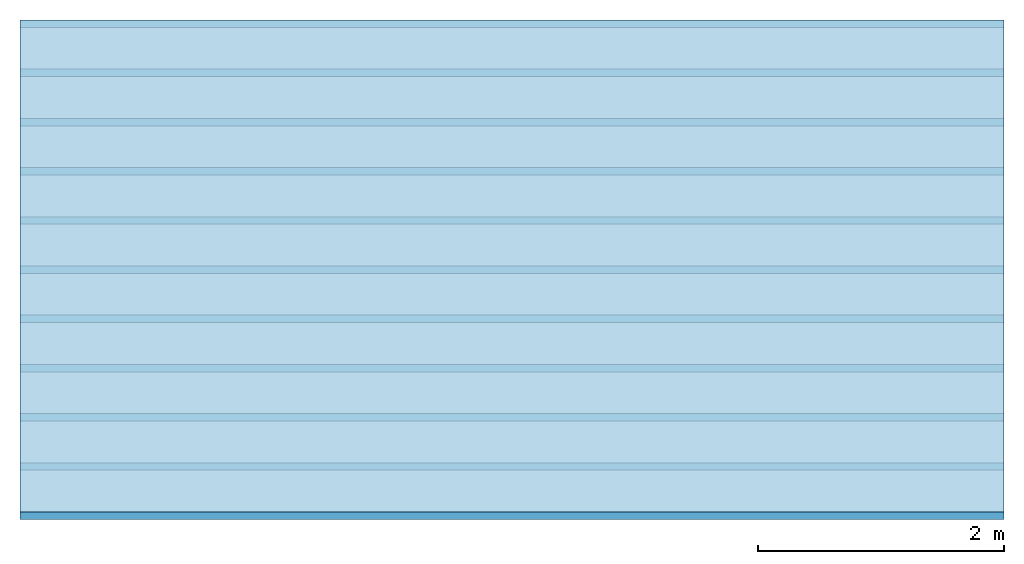
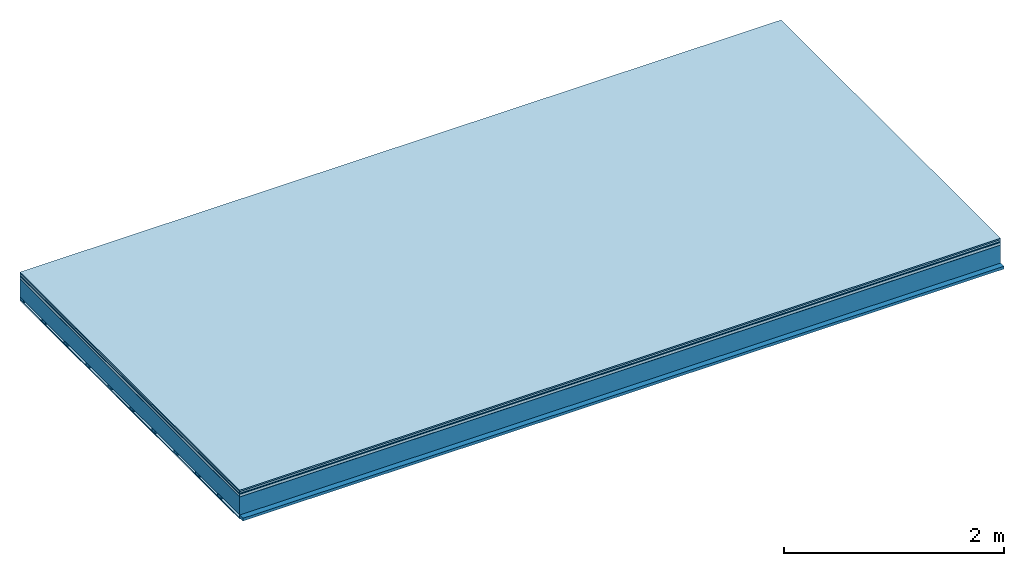
# One storey: 7 plates, 2 members, 1 element without a shape of its own.
"""IFC4 building model written with IfcOpenShell, lengths in metres."""

from ifc_helpers import new_model, si_unit, derived_unit, direction, frame, frame_2d, origin, origin_with_axes, place, context, project, spatial, rectangle, extrude, material, layer, layer_set, type_object, element, aggregate, save


model = new_model("IFC4")

# Units and contexts
plan_context = context("Plan", 3, precision=1e-05, world=origin(), true_north=direction((0.0, 1.0)))
model_context = context("Model", 3, precision=1e-05, world=origin(), true_north=direction((0.0, 1.0)))
ifc_project = project(units=[si_unit("LENGTHUNIT", "METRE"), derived_unit("SOUNDPRESSUREUNIT", [(si_unit("PRESSUREUNIT", "PASCAL", prefix="MICRO"), 0)]), si_unit("ENERGYUNIT", "JOULE", prefix="MEGA"), si_unit("MASSUNIT", "GRAM", prefix="KILO"), derived_unit("THERMALTRANSMITTANCEUNIT", [(si_unit("POWERUNIT", "WATT"), 1), (si_unit("AREAUNIT", "SQUARE_METRE"), -1), (si_unit("THERMODYNAMICTEMPERATUREUNIT", "KELVIN"), -1)]), derived_unit("AREADENSITYUNIT", [(si_unit("MASSUNIT", "GRAM", prefix="KILO"), 1), (si_unit("AREAUNIT", "SQUARE_METRE"), -1)]), derived_unit("USERDEFINED", [(si_unit("ENERGYUNIT", "JOULE", prefix="MEGA"), 1), (si_unit("AREAUNIT", "SQUARE_METRE"), -1)])], contexts=[plan_context, model_context])

# Site, building, storey
site = spatial("IfcSite", under=ifc_project)
building_placement = place(None, origin())
building = spatial("IfcBuilding", under=site, at=building_placement)
storey_placement = place(building_placement, origin())
storey = spatial("IfcBuildingStorey", under=building, at=storey_placement)

# Slab, members, plates
ifc_material_1 = material(Category="11.013")
ifc_layer_1 = layer(ifc_material_1, 0.015, Name="Flooring")
ifc_material_2 = material(Category="03.007")
ifc_layer_2 = layer(ifc_material_2, 0.02, Name="On-material")
ifc_material_3 = material(Name="Wood fiber generic product", Category="10.009")
ifc_layer_3 = layer(ifc_material_3, 0.01, Name="Impact sound insulation")
ifc_material_4 = material(Name="with broken")
ifc_layer_4 = layer(ifc_material_4, 0.03, Name="on Supporting structure")
ifc_material_5 = material(Name="protection", Category="09.007")
ifc_layer_5 = layer(ifc_material_5, 0.0005, Name="Sub-floor")
ifc_material_6 = material(Name="no composite action")
ifc_layer_6 = layer(ifc_material_6, 0.0, Name="Bond")
ifc_layer_7 = layer(None, 0.2, Name="Supporting structure")
ifc_material_7 = material(Name="of the art")
ifc_layer_8 = layer(ifc_material_7, 0.0, Name="Bond")
ifc_layer_9 = layer(None, 0.03, Name="Battens / profiles")
ifc_material_8 = material(Name="Plasterboard type A", Category="03.008")
ifc_layer_10 = layer(ifc_material_8, 0.0125, Name="Ceiling covering 1st layer")
ifc_material_9 = material(Category="04.001")
ifc_layer_11 = layer(ifc_material_9, 0.003, Name="Surface / treatment")
ifc_layer_set = layer_set([ifc_layer_1, ifc_layer_2, ifc_layer_3, ifc_layer_4, ifc_layer_5, ifc_layer_6, ifc_layer_7, ifc_layer_8, ifc_layer_9, ifc_layer_10, ifc_layer_11])
slab_type = type_object("IfcSlabType", Name="A2109", PredefinedType="NOTDEFINED", material=ifc_layer_set)
slab_placement = place(None, frame((0.0, 0.0, 0.0), z_axis=(0.0, 0.0, -1.0), x_axis=(1.0, 0.0, 0.0)))
slab = element("IfcSlab", 1, at=slab_placement, inside=storey, type_object=slab_type, material=ifc_layer_set, Name="Slab #1")
ifc_material_10 = material(Name="Solid timber panel")
member_1_placement = place(slab_placement, origin())
member_1 = element("IfcMember", 2, at=member_1_placement, material=ifc_material_10, Name="Supporting structure", context=plan_context, shape_type="SweptSolid", body=[
    extrude(rectangle(XDim=1.0, YDim=0.2, at=frame_2d((0.5, 0.1), x_axis=(1.0, 0.0))), frame((0.0, 4.0, 0.0755), z_axis=(0.0, -1.0, 0.0), x_axis=(1.0, 0.0, 0.0)), (0.0, 0.0, 1.0), 4.0),
    extrude(rectangle(XDim=1.0, YDim=0.2, at=frame_2d((0.5, 0.1), x_axis=(1.0, 0.0))), frame((1.0, 4.0, 0.0755), z_axis=(0.0, -1.0, 0.0), x_axis=(1.0, 0.0, 0.0)), (0.0, 0.0, 1.0), 4.0),
    extrude(rectangle(XDim=1.0, YDim=0.2, at=frame_2d((0.5, 0.1), x_axis=(1.0, 0.0))), frame((2.0, 4.0, 0.0755), z_axis=(0.0, -1.0, 0.0), x_axis=(1.0, 0.0, 0.0)), (0.0, 0.0, 1.0), 4.0),
    extrude(rectangle(XDim=1.0, YDim=0.2, at=frame_2d((0.5, 0.1), x_axis=(1.0, 0.0))), frame((3.0, 4.0, 0.0755), z_axis=(0.0, -1.0, 0.0), x_axis=(1.0, 0.0, 0.0)), (0.0, 0.0, 1.0), 4.0),
    extrude(rectangle(XDim=1.0, YDim=0.2, at=frame_2d((0.5, 0.1), x_axis=(1.0, 0.0))), frame((4.0, 4.0, 0.0755), z_axis=(0.0, -1.0, 0.0), x_axis=(1.0, 0.0, 0.0)), (0.0, 0.0, 1.0), 4.0),
    extrude(rectangle(XDim=1.0, YDim=0.2, at=frame_2d((0.5, 0.1), x_axis=(1.0, 0.0))), frame((5.0, 4.0, 0.0755), z_axis=(0.0, -1.0, 0.0), x_axis=(1.0, 0.0, 0.0)), (0.0, 0.0, 1.0), 4.0),
    extrude(rectangle(XDim=1.0, YDim=0.2, at=frame_2d((0.5, 0.1), x_axis=(1.0, 0.0))), frame((6.0, 4.0, 0.0755), z_axis=(0.0, -1.0, 0.0), x_axis=(1.0, 0.0, 0.0)), (0.0, 0.0, 1.0), 4.0),
    extrude(rectangle(XDim=1.0, YDim=0.2, at=frame_2d((0.5, 0.1), x_axis=(1.0, 0.0))), frame((7.0, 4.0, 0.0755), z_axis=(0.0, -1.0, 0.0), x_axis=(1.0, 0.0, 0.0)), (0.0, 0.0, 1.0), 4.0),
])
ifc_material_11 = material()
member_2_placement = place(slab_placement, origin())
member_2 = element("IfcMember", 3, at=member_2_placement, material=ifc_material_11, Name="Battens / profiles", context=plan_context, shape_type="SweptSolid", body=[
    extrude(rectangle(XDim=0.06, YDim=0.03, at=frame_2d((0.03, 0.015), x_axis=(1.0, 0.0))), frame((0.0, 0.0, 0.2755), z_axis=(1.0, 0.0, 0.0), x_axis=(0.0, 1.0, 0.0)), (0.0, 0.0, 1.0), 8.0),
    extrude(rectangle(XDim=0.06, YDim=0.03, at=frame_2d((0.03, 0.015), x_axis=(1.0, 0.0))), frame((0.0, 0.4, 0.2755), z_axis=(1.0, 0.0, 0.0), x_axis=(0.0, 1.0, 0.0)), (0.0, 0.0, 1.0), 8.0),
    extrude(rectangle(XDim=0.06, YDim=0.03, at=frame_2d((0.03, 0.015), x_axis=(1.0, 0.0))), frame((0.0, 0.8, 0.2755), z_axis=(1.0, 0.0, 0.0), x_axis=(0.0, 1.0, 0.0)), (0.0, 0.0, 1.0), 8.0),
    extrude(rectangle(XDim=0.06, YDim=0.03, at=frame_2d((0.03, 0.015), x_axis=(1.0, 0.0))), frame((0.0, 1.2, 0.2755), z_axis=(1.0, 0.0, 0.0), x_axis=(0.0, 1.0, 0.0)), (0.0, 0.0, 1.0), 8.0),
    extrude(rectangle(XDim=0.06, YDim=0.03, at=frame_2d((0.03, 0.015), x_axis=(1.0, 0.0))), frame((0.0, 1.6, 0.2755), z_axis=(1.0, 0.0, 0.0), x_axis=(0.0, 1.0, 0.0)), (0.0, 0.0, 1.0), 8.0),
    extrude(rectangle(XDim=0.06, YDim=0.03, at=frame_2d((0.03, 0.015), x_axis=(1.0, 0.0))), frame((0.0, 2.0, 0.2755), z_axis=(1.0, 0.0, 0.0), x_axis=(0.0, 1.0, 0.0)), (0.0, 0.0, 1.0), 8.0),
    extrude(rectangle(XDim=0.06, YDim=0.03, at=frame_2d((0.03, 0.015), x_axis=(1.0, 0.0))), frame((0.0, 2.4, 0.2755), z_axis=(1.0, 0.0, 0.0), x_axis=(0.0, 1.0, 0.0)), (0.0, 0.0, 1.0), 8.0),
    extrude(rectangle(XDim=0.06, YDim=0.03, at=frame_2d((0.03, 0.015), x_axis=(1.0, 0.0))), frame((0.0, 2.8, 0.2755), z_axis=(1.0, 0.0, 0.0), x_axis=(0.0, 1.0, 0.0)), (0.0, 0.0, 1.0), 8.0),
    extrude(rectangle(XDim=0.06, YDim=0.03, at=frame_2d((0.03, 0.015), x_axis=(1.0, 0.0))), frame((0.0, 3.2, 0.2755), z_axis=(1.0, 0.0, 0.0), x_axis=(0.0, 1.0, 0.0)), (0.0, 0.0, 1.0), 8.0),
    extrude(rectangle(XDim=0.06, YDim=0.03, at=frame_2d((0.03, 0.015), x_axis=(1.0, 0.0))), frame((0.0, 3.6, 0.2755), z_axis=(1.0, 0.0, 0.0), x_axis=(0.0, 1.0, 0.0)), (0.0, 0.0, 1.0), 8.0),
    extrude(rectangle(XDim=0.06, YDim=0.03, at=frame_2d((0.03, 0.015), x_axis=(1.0, 0.0))), frame((0.0, 4.0, 0.2755), z_axis=(1.0, 0.0, 0.0), x_axis=(0.0, 1.0, 0.0)), (0.0, 0.0, 1.0), 8.0),
])
plate_1_placement = place(slab_placement, origin())
plate_1 = element("IfcPlate", 4, at=plate_1_placement, material=ifc_material_1, Name="Flooring", context=plan_context, shape_type="SweptSolid", body=[
    extrude(rectangle(XDim=8.0, YDim=4.0, at=frame_2d((4.0, 2.0), x_axis=(1.0, 0.0))), origin_with_axes(), (0.0, 0.0, 1.0), 0.015),
])
plate_2_placement = place(slab_placement, origin())
plate_2 = element("IfcPlate", 5, at=plate_2_placement, material=ifc_material_2, Name="On-material", context=plan_context, shape_type="SweptSolid", body=[
    extrude(rectangle(XDim=8.0, YDim=4.0, at=frame_2d((4.0, 2.0), x_axis=(1.0, 0.0))), frame((0.0, 0.0, 0.015), z_axis=(0.0, 0.0, 1.0), x_axis=(1.0, 0.0, 0.0)), (0.0, 0.0, 1.0), 0.02),
])
plate_3_placement = place(slab_placement, origin())
plate_3 = element("IfcPlate", 6, at=plate_3_placement, material=ifc_material_3, Name="Impact sound insulation", context=plan_context, shape_type="SweptSolid", body=[
    extrude(rectangle(XDim=8.0, YDim=4.0, at=frame_2d((4.0, 2.0), x_axis=(1.0, 0.0))), frame((0.0, 0.0, 0.035), z_axis=(0.0, 0.0, 1.0), x_axis=(1.0, 0.0, 0.0)), (0.0, 0.0, 1.0), 0.01),
])
plate_4_placement = place(slab_placement, origin())
plate_4 = element("IfcPlate", 7, at=plate_4_placement, material=ifc_material_4, Name="on Supporting structure", context=plan_context, shape_type="SweptSolid", body=[
    extrude(rectangle(XDim=8.0, YDim=4.0, at=frame_2d((4.0, 2.0), x_axis=(1.0, 0.0))), frame((0.0, 0.0, 0.045), z_axis=(0.0, 0.0, 1.0), x_axis=(1.0, 0.0, 0.0)), (0.0, 0.0, 1.0), 0.03),
])
plate_5_placement = place(slab_placement, origin())
plate_5 = element("IfcPlate", 8, at=plate_5_placement, material=ifc_material_5, Name="Sub-floor", context=plan_context, shape_type="SweptSolid", body=[
    extrude(rectangle(XDim=8.0, YDim=4.0, at=frame_2d((4.0, 2.0), x_axis=(1.0, 0.0))), frame((0.0, 0.0, 0.075), z_axis=(0.0, 0.0, 1.0), x_axis=(1.0, 0.0, 0.0)), (0.0, 0.0, 1.0), 0.0005),
])
plate_6_placement = place(slab_placement, origin())
plate_6 = element("IfcPlate", 9, at=plate_6_placement, material=ifc_material_8, Name="Ceiling covering 1st layer", context=plan_context, shape_type="SweptSolid", body=[
    extrude(rectangle(XDim=8.0, YDim=4.0, at=frame_2d((4.0, 2.0), x_axis=(1.0, 0.0))), frame((0.0, 0.0, 0.3055), z_axis=(0.0, 0.0, 1.0), x_axis=(1.0, 0.0, 0.0)), (0.0, 0.0, 1.0), 0.0125),
])
plate_7_placement = place(slab_placement, origin())
plate_7 = element("IfcPlate", 10, at=plate_7_placement, material=ifc_material_9, Name="Surface / treatment", context=plan_context, shape_type="SweptSolid", body=[
    extrude(rectangle(XDim=8.0, YDim=4.0, at=frame_2d((4.0, 2.0), x_axis=(1.0, 0.0))), frame((0.0, 0.0, 0.318), z_axis=(0.0, 0.0, 1.0), x_axis=(1.0, 0.0, 0.0)), (0.0, 0.0, 1.0), 0.003),
])
aggregate(slab, [plate_1, plate_2, plate_3, plate_4, plate_5, member_1, member_2, plate_6, plate_7])

save(model, "model.ifc")
